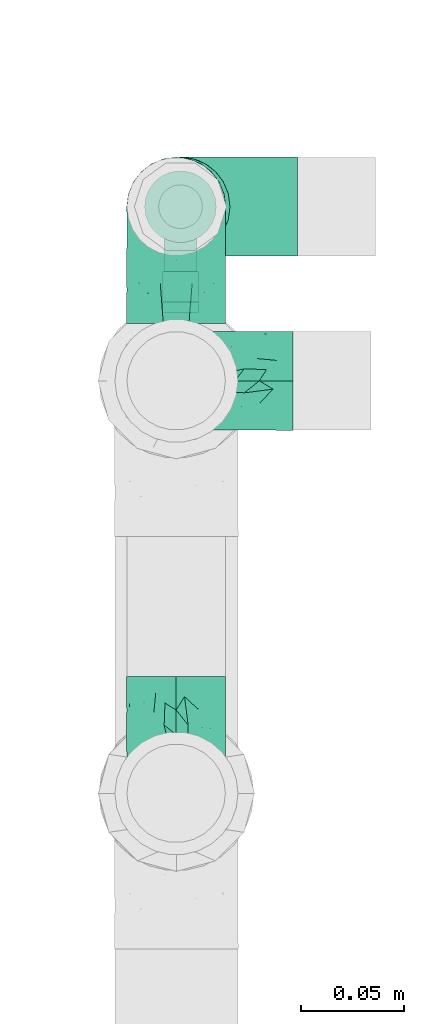
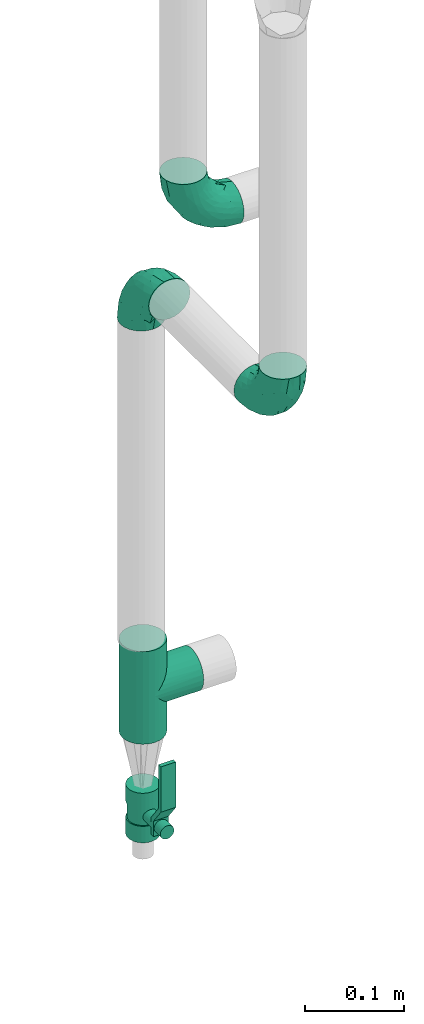
# One storey, part 569 of 827: 4 flow fittings, 1 flow controller.
"""IFC2X3 building model written with IfcOpenShell, lengths in millimetres."""

from ifc_helpers import new_model, entity, si_unit, converted_unit, derived_unit, direction, frame, origin, origin_2d_with_axis, place, context, subcontext, project, spatial, polyline, circle, outline, extrude, faceted_brep, source, transform, mapped, material, material_list, type_object, type_shapes, element, save


model = new_model("IFC2X3")

# Units and contexts
model_context = context("Model", 3, precision=0.01, world=origin(), true_north=direction((6.12303176911189e-17, 1.0)))
body_context = subcontext(model_context, "Body", "Model", "MODEL_VIEW")
ifc_project = project(units=[si_unit("LENGTHUNIT", "METRE", prefix="MILLI"), si_unit("AREAUNIT", "SQUARE_METRE"), si_unit("VOLUMEUNIT", "CUBIC_METRE"), converted_unit("PLANEANGLEUNIT", "DEGREE", entity("IfcRatioMeasure", 0.0174532925199433), si_unit("PLANEANGLEUNIT", "RADIAN"), dimensions=[0, 0, 0, 0, 0, 0, 0]), si_unit("MASSUNIT", "GRAM", prefix="KILO"), derived_unit("MASSDENSITYUNIT", [(si_unit("MASSUNIT", "GRAM", prefix="KILO"), 1), (si_unit("LENGTHUNIT", "METRE"), -3)]), derived_unit("MOMENTOFINERTIAUNIT", [(si_unit("LENGTHUNIT", "METRE"), 4)]), si_unit("TIMEUNIT", "SECOND"), si_unit("FREQUENCYUNIT", "HERTZ"), si_unit("THERMODYNAMICTEMPERATUREUNIT", "DEGREE_CELSIUS"), derived_unit("THERMALTRANSMITTANCEUNIT", [(si_unit("MASSUNIT", "GRAM", prefix="KILO"), 1), (si_unit("THERMODYNAMICTEMPERATUREUNIT", "KELVIN"), -1), (si_unit("TIMEUNIT", "SECOND"), -3)]), derived_unit("VOLUMETRICFLOWRATEUNIT", [(si_unit("LENGTHUNIT", "METRE"), 3), (si_unit("TIMEUNIT", "SECOND"), -1)]), derived_unit("MASSFLOWRATEUNIT", [(si_unit("MASSUNIT", "GRAM", prefix="KILO"), 1), (si_unit("TIMEUNIT", "SECOND"), -1)]), derived_unit("ROTATIONALFREQUENCYUNIT", [(si_unit("TIMEUNIT", "SECOND"), -1)]), si_unit("ELECTRICCURRENTUNIT", "AMPERE"), si_unit("ELECTRICVOLTAGEUNIT", "VOLT"), si_unit("POWERUNIT", "WATT"), si_unit("FORCEUNIT", "NEWTON", prefix="KILO"), si_unit("ILLUMINANCEUNIT", "LUX"), si_unit("LUMINOUSFLUXUNIT", "LUMEN"), si_unit("LUMINOUSINTENSITYUNIT", "CANDELA"), derived_unit("USERDEFINED", [(si_unit("MASSUNIT", "GRAM", prefix="KILO"), -1), (si_unit("LENGTHUNIT", "METRE"), -2), (si_unit("TIMEUNIT", "SECOND"), 3), (si_unit("LUMINOUSFLUXUNIT", "LUMEN"), 1)]), derived_unit("LINEARVELOCITYUNIT", [(si_unit("LENGTHUNIT", "METRE"), 1), (si_unit("TIMEUNIT", "SECOND"), -1)]), si_unit("PRESSUREUNIT", "PASCAL"), derived_unit("USERDEFINED", [(si_unit("LENGTHUNIT", "METRE"), -2), (si_unit("MASSUNIT", "GRAM", prefix="KILO"), 1), (si_unit("TIMEUNIT", "SECOND"), -2)]), derived_unit("LINEARFORCEUNIT", [(si_unit("MASSUNIT", "GRAM", prefix="KILO"), 1), (si_unit("LENGTHUNIT", "METRE"), 1), (si_unit("TIMEUNIT", "SECOND"), -2), (si_unit("LENGTHUNIT", "METRE"), -1)]), derived_unit("PLANARFORCEUNIT", [(si_unit("MASSUNIT", "GRAM", prefix="KILO"), 1), (si_unit("LENGTHUNIT", "METRE"), 1), (si_unit("TIMEUNIT", "SECOND"), -2), (si_unit("LENGTHUNIT", "METRE"), -2)])], contexts=[model_context])

# Site, building, storey
site_placement = place(None, origin())
site = spatial("IfcSite", under=ifc_project, at=site_placement, CompositionType="ELEMENT")
building_placement = place(site_placement, origin())
building = spatial("IfcBuilding", under=site, at=building_placement, CompositionType="ELEMENT")
storey_placement = place(building_placement, frame((0.0, 0.0, 28200.0)))
storey = spatial("IfcBuildingStorey", under=building, at=storey_placement, Name="08", CompositionType="ELEMENT", Elevation=28200.0)

# Flow controller
ifc_material = material()
ifc_material_list = material_list([ifc_material, ifc_material, ifc_material, ifc_material, ifc_material])
valve_type = type_object("IfcValveType", PredefinedType="NOTDEFINED", material=ifc_material_list)
shared_shape_1 = source(origin(), body_context, "Body", "SweptSolid", [
    extrude(circle(Radius=17.5, at=origin_2d_with_axis()), frame((-30.5, 0.0, 0.0), z_axis=(1.0, 0.0, 0.0), x_axis=(0.0, 1.0, 0.0)), (0.0, 0.0, 1.0), 20.3333333333333),
    extrude(circle(Radius=16.0, at=origin_2d_with_axis()), frame((-10.17, 0.0, 0.0), z_axis=(1.0, 0.0, 0.0), x_axis=(0.0, 1.0, 0.0)), (0.0, 0.0, 1.0), 20.3333333333333),
    extrude(circle(Radius=17.5, at=origin_2d_with_axis()), frame((10.17, 0.0, 0.0), z_axis=(1.0, 0.0, 0.0), x_axis=(0.0, 1.0, 0.0)), (0.0, 0.0, 1.0), 20.3333333333333),
    extrude(outline(polyline([(-38.75, -5.0), (-38.75, -10.0), (-17.92, -10.0), (2.08, 5.0), (56.25, 5.0), (56.25, 10.0), (0.42, 10.0), (-19.58, -5.0), (-38.75, -5.0)])), frame((28.75, -8.75, 41.5), z_axis=(0.0, -1.0, 0.0), x_axis=(1.0, 0.0, 0.0)), (0.0, 0.0, -1.0), 17.5),
    extrude(circle(Radius=8.0, at=origin_2d_with_axis()), origin(), (0.0, 0.0, 1.0), 49.0),
])
type_shapes(valve_type, [shared_shape_1])
flow_controller_placement = place(storey_placement, frame((15027.91, 15604.11, 250.0), z_axis=(0.0, -1.0, 0.0), x_axis=(0.0, 0.0, 1.0)))
element("IfcFlowController", 1, at=flow_controller_placement, inside=storey, type_object=valve_type, material=ifc_material, context=body_context, shape_type="MappedRepresentation", body=[
    mapped(shared_shape_1, transform((0.0, 0.0, 0.0), scale=1.0)),
])

# Flow fittings
pipe_fitting_type_1 = type_object("IfcPipeFittingType", Name="ADSK_1", PredefinedType="NOTDEFINED", material=ifc_material)
shared_shape_2 = source(origin(), body_context, "Body", "Brep", [
    faceted_brep([(-57.0, 12.07, -20.91), (-57.0, 6.25, -23.33), (-57.0, 0.0, -24.15), (-57.0, -6.25, -23.33), (-57.0, -12.08, -20.91), (-57.0, -17.08, -17.08), (-57.0, -20.91, -12.08), (-57.0, -23.33, -6.25), (-57.0, -24.15, 0.0), (-57.0, -23.33, 6.25), (-57.0, -20.91, 12.07), (-57.0, -17.08, 17.08), (-57.0, -12.08, 20.91), (-57.0, -6.25, 23.33), (-57.0, 0.0, 24.15), (-57.0, 6.25, 23.33), (-57.0, 12.07, 20.91), (-57.0, 17.08, 17.08), (-57.0, 20.91, 12.07), (-57.0, 23.33, 6.25), (-57.0, 24.15, 0.0), (-57.0, 23.33, -6.25), (-57.0, 20.91, -12.08), (-57.0, 17.08, -17.08), (0.0, 57.0, -24.15), (-6.25, 57.0, -23.33), (-12.07, 57.0, -20.91), (-17.08, 57.0, -17.08), (-20.91, 57.0, -12.08), (-23.33, 57.0, -6.25), (-24.15, 57.0, 0.0), (-23.33, 57.0, 6.25), (-20.91, 57.0, 12.07), (-17.08, 57.0, 17.08), (-12.07, 57.0, 20.91), (-6.25, 57.0, 23.33), (0.0, 57.0, 24.15), (6.25, 57.0, 23.33), (12.08, 57.0, 20.91), (17.08, 57.0, 17.08), (20.91, 57.0, 12.07), (23.33, 57.0, 6.25), (24.15, 57.0, 0.0), (23.33, 57.0, -6.25), (20.91, 57.0, -12.08), (17.08, 57.0, -17.08), (12.08, 57.0, -20.91), (6.25, 57.0, -23.33), (14.9, 21.14, 6.17), (13.61, 24.64, 12.48), (6.23, 8.95, 8.98), (-41.47, -21.06, 0.0), (-41.92, -18.38, 13.72), (-24.64, -13.61, 12.48), (-37.37, -13.24, 18.15), (-6.8, -4.93, 8.18), (-21.76, -15.19, 6.22), (-12.78, -9.18, 0.0), (-37.73, -20.51, 7.75), (-7.38, 7.38, 20.24), (-23.37, -4.26, 20.42), (-11.9, -3.19, 15.86), (-42.14, -8.7, 21.82), (13.24, 37.37, 18.15), (9.33, 23.53, 16.85), (4.26, 23.37, 20.42), (2.77, 10.92, 15.55), (-29.46, 0.91, 23.52), (-44.13, 20.56, 15.69), (-39.25, 26.33, 10.88), (-49.02, 22.92, 9.96), (-34.58, 23.87, 17.15), (-15.8, 6.8, 22.81), (-8.67, 20.47, 23.88), (-18.12, 12.9, 24.08), (-48.29, 14.92, 19.65), (-44.06, -2.85, 23.78), (-9.23, 48.95, 22.58), (-3.78, 42.74, 24.07), (-40.34, 4.26, 24.09), (-44.02, 26.14, 5.46), (-44.04, 9.88, 22.74), (-4.95, 16.87, 22.52), (-2.75, 1.43, 12.5), (-25.48, 40.98, 10.71), (20.51, 37.73, 7.75), (18.38, 41.92, 13.72), (8.7, 42.14, 21.82), (-25.95, -17.97, 0.0), (2.85, 44.06, 23.78), (21.06, 41.47, 0.0), (17.97, 25.95, 0.0), (-24.04, -9.27, 17.13), (-33.26, 33.26, 5.86), (-28.55, 40.57, 0.0), (-40.57, 28.55, 0.0), (-25.29, 47.19, 4.06), (-27.01, 31.1, 16.77), (-15.7, 43.95, 19.9), (-20.27, 45.22, 15.61), (-30.53, 31.98, 12.64), (-11.28, 38.33, 22.92), (-9.97, 27.88, 24.09), (-20.15, 30.26, 21.25), (-31.25, 11.75, 23.64), (-28.75, 7.23, 24.15), (-29.53, 18.06, 22.27), (-28.44, 24.21, 20.02), (-37.55, 17.7, 20.26), (-15.88, 29.25, 22.99), (-20.82, 20.82, 23.44), (-0.91, 29.46, 23.52), (-13.5, -7.67, 12.04), (1.49, 1.56, 5.16), (8.86, 10.35, 4.59), (0.38, -0.38, 0.0), (9.18, 12.78, 0.0), (-37.37, -13.24, -18.15), (8.86, 10.35, -4.59), (-45.22, 20.27, -15.61), (-43.95, 15.7, -19.9), (-38.33, 11.28, -22.92), (-48.95, 9.23, -22.58), (-47.19, 25.29, -4.06), (-33.26, 33.26, -5.86), (18.38, 41.92, -13.72), (-30.26, 20.15, -21.25), (2.85, 44.06, -23.78), (-4.26, 40.34, -24.09), (-40.98, 25.48, -10.71), (-41.92, -18.38, -13.72), (9.25, 23.5, -16.92), (4.26, 23.37, -20.42), (13.24, 37.37, -18.15), (-37.73, -20.51, -7.75), (-11.75, 31.25, -23.64), (-7.23, 28.75, -24.15), (-12.9, 18.12, -24.08), (8.7, 42.14, -21.82), (-44.06, -2.85, -23.78), (-6.8, 15.8, -22.81), (-20.47, 8.67, -23.88), (-24.64, -13.61, -12.48), (-42.74, 3.78, -24.07), (-18.06, 29.53, -22.27), (-24.21, 28.44, -20.02), (-27.88, 9.97, -24.09), (-31.1, 27.01, -16.77), (-26.14, 44.02, -5.46), (14.9, 21.14, -6.17), (20.51, 37.73, -7.75), (-9.88, 44.04, -22.74), (-20.56, 44.13, -15.69), (-21.76, -15.19, -6.22), (-13.5, -7.67, -12.04), (-24.14, -9.76, -16.74), (-11.9, -3.19, -15.86), (-14.92, 48.29, -19.65), (-23.37, -4.26, -20.42), (-0.91, 29.46, -23.52), (-26.33, 39.25, -10.88), (-23.87, 34.58, -17.15), (-42.14, -8.7, -21.82), (-22.92, 49.02, -9.96), (13.61, 24.64, -12.48), (-31.98, 30.53, -12.64), (-16.87, 4.95, -22.52), (-17.7, 37.55, -20.26), (-29.25, 15.88, -22.99), (-20.82, 20.82, -23.44), (-29.46, 0.91, -23.52), (-7.38, 7.38, -20.24), (2.77, 10.92, -15.55), (6.23, 8.95, -8.98), (-6.8, -4.93, -8.18), (-2.81, 1.41, -12.54), (1.49, 1.56, -5.16)], [[[0, 1, 2, 3, 4, 5, 6, 7, 8, 9, 10, 11, 12, 13, 14, 15, 16, 17, 18, 19, 20, 21, 22, 23]], [[24, 25, 26, 27, 28, 29, 30, 31, 32, 33, 34, 35, 36, 37, 38, 39, 40, 41, 42, 43, 44, 45, 46, 47]], [[48, 49, 50]], [[9, 8, 51]], [[52, 53, 54]], [[55, 56, 57]], [[10, 58, 52]], [[9, 58, 10]], [[59, 60, 61]], [[54, 12, 11]], [[54, 62, 12]], [[63, 39, 38]], [[64, 65, 66]], [[62, 60, 67]], [[68, 69, 70]], [[71, 69, 68]], [[72, 73, 74]], [[16, 75, 17]], [[13, 76, 14]], [[35, 77, 78]], [[14, 79, 15]], [[17, 68, 18]], [[14, 76, 79]], [[20, 19, 80]], [[70, 19, 18]], [[81, 15, 79]], [[15, 81, 16]], [[73, 72, 82]], [[66, 83, 50]], [[32, 31, 84]], [[85, 86, 49]], [[63, 87, 65]], [[56, 58, 88]], [[36, 89, 37]], [[85, 41, 40]], [[36, 35, 78]], [[90, 41, 85]], [[40, 39, 86]], [[12, 62, 13]], [[86, 85, 40]], [[48, 85, 49]], [[85, 91, 90]], [[87, 38, 37]], [[92, 60, 54]], [[80, 69, 93]], [[93, 94, 95]], [[10, 52, 11]], [[94, 96, 30]], [[97, 98, 99]], [[80, 93, 95]], [[100, 97, 84]], [[99, 98, 33]], [[101, 102, 78]], [[103, 101, 98]], [[96, 31, 30]], [[77, 98, 101]], [[77, 35, 34]], [[34, 33, 98]], [[9, 51, 58]], [[87, 63, 38]], [[104, 105, 74]], [[106, 103, 107]], [[106, 81, 104]], [[75, 68, 17]], [[108, 107, 71]], [[33, 32, 99]], [[109, 103, 110]], [[101, 109, 102]], [[89, 78, 111]], [[53, 52, 58]], [[54, 11, 52]], [[60, 62, 54]], [[88, 58, 51]], [[76, 62, 67]], [[53, 112, 92]], [[60, 59, 72]], [[39, 63, 86]], [[49, 86, 63]], [[89, 87, 37]], [[42, 41, 90]], [[111, 82, 65]], [[111, 65, 87]], [[65, 59, 66]], [[104, 81, 79]], [[75, 81, 108]], [[32, 84, 99]], [[97, 99, 84]], [[98, 97, 103]], [[106, 107, 108]], [[74, 102, 110]], [[111, 78, 102]], [[74, 110, 104]], [[74, 67, 72]], [[61, 92, 112]], [[66, 59, 61]], [[56, 53, 58]], [[66, 50, 49]], [[61, 112, 83]], [[66, 49, 64]], [[78, 89, 36]], [[87, 89, 111]], [[62, 76, 13]], [[79, 76, 67]], [[100, 93, 69]], [[96, 93, 84]], [[55, 113, 50]], [[113, 114, 50]], [[104, 79, 105]], [[106, 104, 110]], [[20, 80, 95]], [[85, 48, 91]], [[115, 114, 113]], [[116, 91, 48]], [[70, 80, 19]], [[93, 96, 94]], [[84, 31, 96]], [[103, 106, 110]], [[81, 106, 108]], [[103, 97, 107]], [[71, 107, 97]], [[71, 97, 100]], [[108, 71, 68]], [[79, 67, 105]], [[67, 74, 105]], [[115, 113, 57]], [[112, 56, 55]], [[56, 88, 57]], [[60, 72, 67]], [[82, 72, 59]], [[65, 82, 59]], [[82, 111, 73]], [[111, 102, 73]], [[102, 74, 73]], [[81, 75, 16]], [[68, 75, 108]], [[68, 70, 18]], [[80, 70, 69]], [[98, 77, 34]], [[78, 77, 101]], [[93, 100, 84]], [[71, 100, 69]], [[102, 109, 110]], [[101, 103, 109]], [[53, 92, 54]], [[61, 60, 92]], [[56, 112, 53]], [[83, 112, 55]], [[50, 83, 55]], [[61, 83, 66]], [[49, 63, 64]], [[65, 64, 63]], [[57, 113, 55]], [[114, 115, 116]], [[116, 48, 114]], [[48, 50, 114]], [[117, 5, 4]], [[116, 115, 118]], [[119, 120, 23]], [[121, 122, 120]], [[95, 123, 20]], [[0, 23, 120]], [[124, 95, 94]], [[125, 45, 44]], [[121, 120, 126]], [[24, 127, 128]], [[22, 21, 129]], [[0, 122, 1]], [[5, 117, 130]], [[131, 132, 133]], [[134, 88, 51]], [[135, 136, 137]], [[6, 5, 130]], [[46, 138, 47]], [[139, 3, 2]], [[140, 141, 137]], [[6, 134, 7]], [[134, 130, 142]], [[143, 2, 1]], [[144, 126, 145]], [[121, 146, 143]], [[147, 120, 119]], [[94, 148, 124]], [[149, 150, 91]], [[30, 29, 148]], [[151, 25, 128]], [[27, 152, 28]], [[134, 153, 88]], [[154, 155, 156]], [[27, 26, 157]], [[151, 26, 25]], [[155, 158, 156]], [[24, 47, 127]], [[1, 122, 143]], [[138, 132, 159]], [[160, 152, 161]], [[24, 128, 25]], [[46, 133, 138]], [[162, 117, 4]], [[148, 160, 124]], [[152, 160, 163]], [[154, 142, 155]], [[45, 125, 133]], [[133, 46, 45]], [[125, 164, 133]], [[51, 7, 134]], [[42, 90, 43]], [[165, 147, 129]], [[153, 134, 142]], [[43, 150, 44]], [[162, 4, 3]], [[141, 140, 166]], [[117, 162, 158]], [[163, 29, 28]], [[43, 90, 150]], [[123, 21, 20]], [[144, 151, 135]], [[157, 152, 27]], [[167, 145, 161]], [[23, 22, 119]], [[168, 126, 169]], [[121, 168, 146]], [[139, 143, 170]], [[142, 130, 117]], [[8, 7, 51]], [[134, 6, 130]], [[139, 162, 3]], [[170, 166, 158]], [[170, 158, 162]], [[158, 171, 156]], [[44, 150, 125]], [[91, 150, 90]], [[164, 125, 150]], [[132, 138, 133]], [[127, 138, 159]], [[131, 164, 172]], [[132, 171, 140]], [[135, 151, 128]], [[157, 151, 167]], [[22, 129, 119]], [[147, 119, 129]], [[120, 147, 126]], [[144, 145, 167]], [[137, 146, 169]], [[170, 143, 146]], [[137, 169, 135]], [[137, 159, 140]], [[171, 172, 156]], [[173, 174, 175]], [[156, 175, 154]], [[174, 57, 153]], [[132, 172, 171]], [[172, 164, 173]], [[143, 139, 2]], [[162, 139, 170]], [[138, 127, 47]], [[128, 127, 159]], [[165, 124, 160]], [[123, 124, 129]], [[149, 173, 164]], [[176, 174, 173]], [[135, 128, 136]], [[144, 135, 169]], [[150, 149, 164]], [[176, 118, 115]], [[149, 91, 116]], [[30, 148, 94]], [[163, 148, 29]], [[124, 123, 95]], [[129, 21, 123]], [[126, 144, 169]], [[151, 144, 167]], [[126, 147, 145]], [[161, 145, 147]], [[161, 147, 165]], [[167, 161, 152]], [[128, 159, 136]], [[159, 137, 136]], [[154, 153, 142]], [[132, 140, 159]], [[174, 176, 57]], [[57, 88, 153]], [[166, 140, 171]], [[158, 166, 171]], [[166, 170, 141]], [[170, 146, 141]], [[146, 137, 141]], [[151, 157, 26]], [[152, 157, 167]], [[152, 163, 28]], [[148, 163, 160]], [[120, 122, 0]], [[143, 122, 121]], [[124, 165, 129]], [[161, 165, 160]], [[146, 168, 169]], [[121, 126, 168]], [[142, 117, 155]], [[158, 155, 117]], [[175, 156, 172]], [[153, 154, 174]], [[173, 175, 172]], [[174, 154, 175]], [[164, 131, 133]], [[172, 132, 131]], [[176, 173, 118]], [[57, 176, 115]], [[173, 149, 118]], [[149, 116, 118]]]),
])
type_shapes(pipe_fitting_type_1, [shared_shape_2])
for number, where, z_axis, x_axis, name in (
    (2, (15025.81, 15318.04, 912.08), (1.0, 0.0, 0.0), (0.0, 0.0, -1.0), "ADSK_1"),
    (3, (15025.81, 15604.11, 912.08), (-1.0, 0.0, 0.0), (0.0, 1.0, 0.0), "ADSK_1"),
    (4, (15025.81, 15519.19, 1030.0), (0.0, -1.0, 0.0), (0.0, 0.0, -1.0), "ADSK_1"),
):
    element("IfcFlowFitting", number, at=place(storey_placement, frame(where, z_axis=z_axis, x_axis=x_axis)), inside=storey, type_object=pipe_fitting_type_1, material=ifc_material, Name=name, ObjectType="ADSK_1", context=body_context, shape_type="MappedRepresentation", body=[
        mapped(shared_shape_2, transform((0.0, 0.0, 0.0), scale=1.0)),
    ])
pipe_fitting_type_2 = type_object("IfcPipeFittingType", Name="ADSK_1", PredefinedType="NOTDEFINED", material=ifc_material)
shared_shape_3 = source(origin(), body_context, "Body", "Brep", [
    faceted_brep([(-57.0, 12.07, -20.91), (-57.0, 6.25, -23.33), (-57.0, 0.0, -24.15), (-57.0, -6.25, -23.33), (-57.0, -12.08, -20.91), (-57.0, -17.08, -17.08), (-57.0, -20.91, -12.08), (-57.0, -23.33, -6.25), (-57.0, -24.15, 0.0), (-57.0, -23.33, 6.25), (-57.0, -20.91, 12.07), (-57.0, -17.08, 17.08), (-57.0, -12.08, 20.91), (-57.0, -6.25, 23.33), (-57.0, 0.0, 24.15), (-57.0, 6.25, 23.33), (-57.0, 12.07, 20.91), (-57.0, 17.08, 17.08), (-57.0, 20.91, 12.07), (-57.0, 23.33, 6.25), (-57.0, 24.15, 0.0), (-57.0, 23.33, -6.25), (-57.0, 20.91, -12.08), (-57.0, 17.08, -17.08), (57.0, 0.0, -24.15), (57.0, 6.25, -23.33), (57.0, 12.07, -20.91), (57.0, 17.08, -17.08), (57.0, 20.91, -12.08), (57.0, 23.33, -6.25), (57.0, 24.15, 0.0), (57.0, 23.33, 6.25), (57.0, 20.91, 12.07), (57.0, 17.08, 17.08), (57.0, 12.07, 20.91), (57.0, 6.25, 23.33), (57.0, 0.0, 24.15), (57.0, -6.25, 23.33), (57.0, -12.08, 20.91), (57.0, -17.08, 17.08), (57.0, -20.91, 12.07), (57.0, -23.33, 6.25), (57.0, -24.15, 0.0), (57.0, -23.33, -6.25), (57.0, -20.91, -12.08), (57.0, -17.08, -17.08), (57.0, -12.08, -20.91), (57.0, -6.25, -23.33), (23.27, -23.27, 6.45), (24.15, -24.15, 0.0), (-24.15, -24.15, 0.0), (20.9, -20.9, 12.1), (13.54, -13.54, 20.0), (17.52, -17.52, 16.62), (-23.27, -23.27, 6.45), (-20.9, -20.9, 12.1), (-17.52, -17.52, 16.62), (-13.54, -13.54, 20.0), (-9.19, -9.19, 22.33), (9.19, -9.19, 22.33), (4.64, -4.64, 23.7), (0.0, 0.0, 24.15), (-4.64, -4.64, 23.7), (4.64, -4.64, -23.7), (0.0, 0.0, -24.15), (-4.64, -4.64, -23.7), (-9.19, -9.19, -22.33), (9.19, -9.19, -22.33), (13.54, -13.54, -20.0), (17.52, -17.52, -16.62), (20.9, -20.9, -12.1), (23.27, -23.27, -6.45), (-13.54, -13.54, -20.0), (-17.52, -17.52, -16.62), (-23.27, -23.27, -6.45), (-20.9, -20.9, -12.1), (0.0, -57.0, -24.15), (6.25, -57.0, -23.33), (12.08, -57.0, -20.91), (17.08, -57.0, -17.08), (20.91, -57.0, -12.08), (23.33, -57.0, -6.25), (24.15, -57.0, 0.0), (23.33, -57.0, 6.25), (20.91, -57.0, 12.07), (17.08, -57.0, 17.08), (12.08, -57.0, 20.91), (6.25, -57.0, 23.33), (0.0, -57.0, 24.15), (-6.25, -57.0, 23.33), (-12.07, -57.0, 20.91), (-17.08, -57.0, 17.08), (-20.91, -57.0, 12.07), (-23.33, -57.0, 6.25), (-24.15, -57.0, 0.0), (-23.33, -57.0, -6.25), (-20.91, -57.0, -12.08), (-17.08, -57.0, -17.08), (-12.07, -57.0, -20.91), (-6.25, -57.0, -23.33)], [[[0, 1, 2, 3, 4, 5, 6, 7, 8, 9, 10, 11, 12, 13, 14, 15, 16, 17, 18, 19, 20, 21, 22, 23]], [[24, 25, 26, 27, 28, 29, 30, 31, 32, 33, 34, 35, 36, 37, 38, 39, 40, 41, 42, 43, 44, 45, 46, 47]], [[41, 40, 48]], [[42, 41, 49]], [[50, 9, 8]], [[49, 41, 48]], [[40, 51, 48]], [[39, 38, 52]], [[51, 40, 53]], [[52, 53, 39]], [[53, 40, 39]], [[50, 54, 9]], [[9, 54, 10]], [[54, 55, 10]], [[56, 57, 11]], [[11, 10, 56]], [[11, 57, 12]], [[56, 10, 55]], [[12, 57, 58]], [[52, 38, 59]], [[60, 36, 61]], [[62, 61, 14]], [[59, 37, 60]], [[37, 59, 38]], [[60, 37, 36]], [[61, 36, 35, 15, 14]], [[32, 31, 19, 18]], [[17, 16, 34, 33]], [[18, 17, 33, 32]], [[35, 34, 16, 15]], [[20, 19, 31, 30]], [[62, 13, 58]], [[13, 62, 14]], [[58, 13, 12]], [[27, 23, 22, 28]], [[22, 21, 29, 28]], [[0, 23, 27, 26]], [[20, 30, 29, 21]], [[24, 47, 63]], [[24, 64, 2, 1, 25]], [[64, 24, 63]], [[2, 64, 65]], [[26, 25, 1, 0]], [[65, 66, 3]], [[2, 65, 3]], [[66, 4, 3]], [[63, 47, 67]], [[46, 45, 68]], [[69, 68, 45]], [[44, 70, 69]], [[69, 45, 44]], [[46, 68, 67]], [[43, 42, 49]], [[7, 50, 8]], [[43, 71, 44]], [[71, 43, 49]], [[44, 71, 70]], [[72, 4, 66]], [[72, 5, 4]], [[5, 72, 73]], [[5, 73, 6]], [[74, 50, 7]], [[75, 74, 6]], [[74, 7, 6]], [[75, 6, 73]], [[46, 67, 47]], [[76, 77, 78, 79, 80, 81, 82, 83, 84, 85, 86, 87, 88, 89, 90, 91, 92, 93, 94, 95, 96, 97, 98, 99]], [[50, 94, 93]], [[54, 50, 93]], [[91, 90, 57]], [[56, 92, 91]], [[54, 93, 92]], [[58, 90, 89]], [[55, 54, 92]], [[56, 55, 92]], [[58, 57, 90]], [[88, 61, 62]], [[58, 89, 62]], [[56, 91, 57]], [[62, 89, 88]], [[60, 88, 87]], [[86, 59, 87]], [[84, 83, 48]], [[53, 85, 84]], [[52, 86, 85]], [[49, 83, 82]], [[59, 60, 87]], [[52, 59, 86]], [[49, 48, 83]], [[51, 53, 84]], [[48, 51, 84]], [[52, 85, 53]], [[88, 60, 61]], [[82, 81, 49]], [[71, 49, 81]], [[69, 80, 79]], [[79, 78, 68]], [[71, 81, 80]], [[67, 78, 77]], [[70, 71, 80]], [[69, 70, 80]], [[67, 68, 78]], [[76, 64, 63]], [[67, 77, 63]], [[69, 79, 68]], [[63, 77, 76]], [[65, 76, 99]], [[98, 66, 99]], [[96, 95, 74]], [[73, 97, 96]], [[72, 98, 97]], [[50, 95, 94]], [[66, 65, 99]], [[72, 66, 98]], [[50, 74, 95]], [[75, 73, 96]], [[74, 75, 96]], [[72, 97, 73]], [[76, 65, 64]]]),
])
type_shapes(pipe_fitting_type_2, [shared_shape_3])
flow_fitting_placement = place(storey_placement, frame((15027.91, 15604.11, 402.5), z_axis=(0.0, -1.0, 0.0), x_axis=(0.0, 0.0, 1.0)))
element("IfcFlowFitting", 5, at=flow_fitting_placement, inside=storey, type_object=pipe_fitting_type_2, material=ifc_material, Name="ADSK_1", ObjectType="ADSK_1", context=body_context, shape_type="MappedRepresentation", body=[
    mapped(shared_shape_3, transform((0.0, 0.0, 0.0), scale=1.0)),
])

save(model, "model.ifc")
